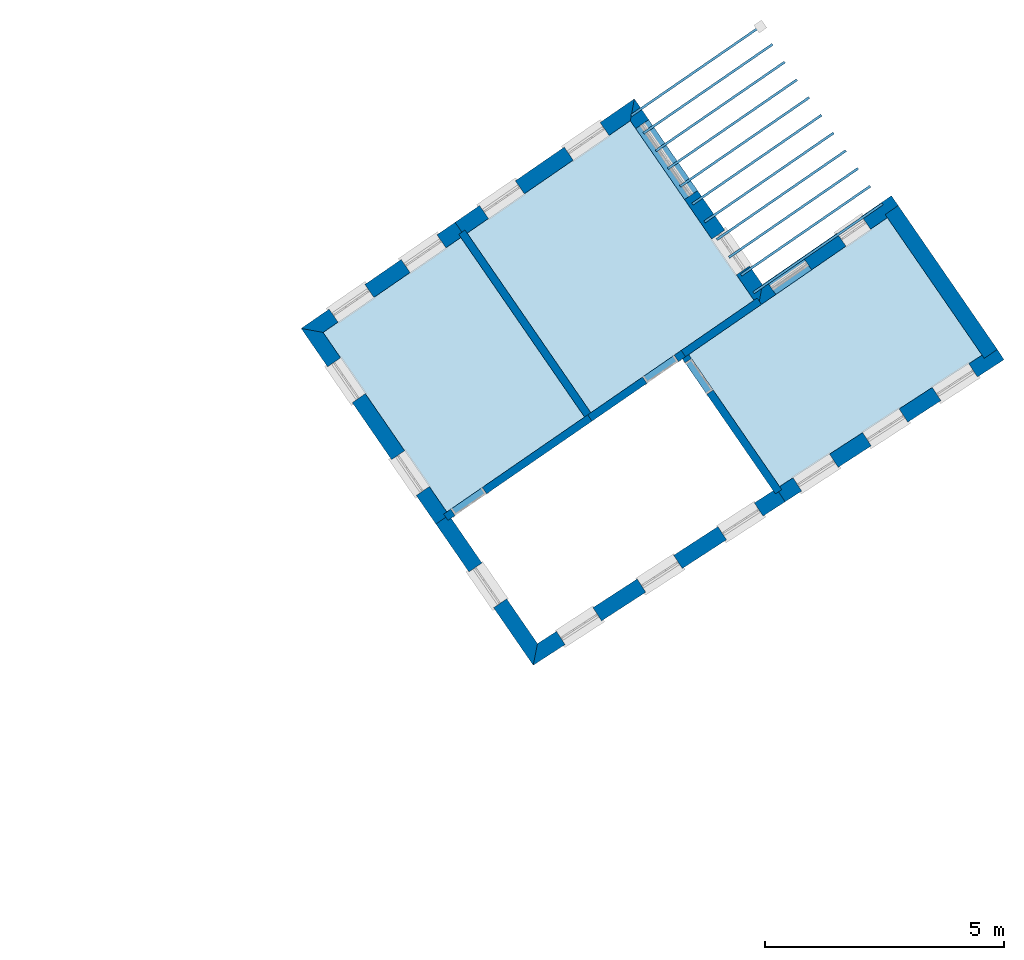
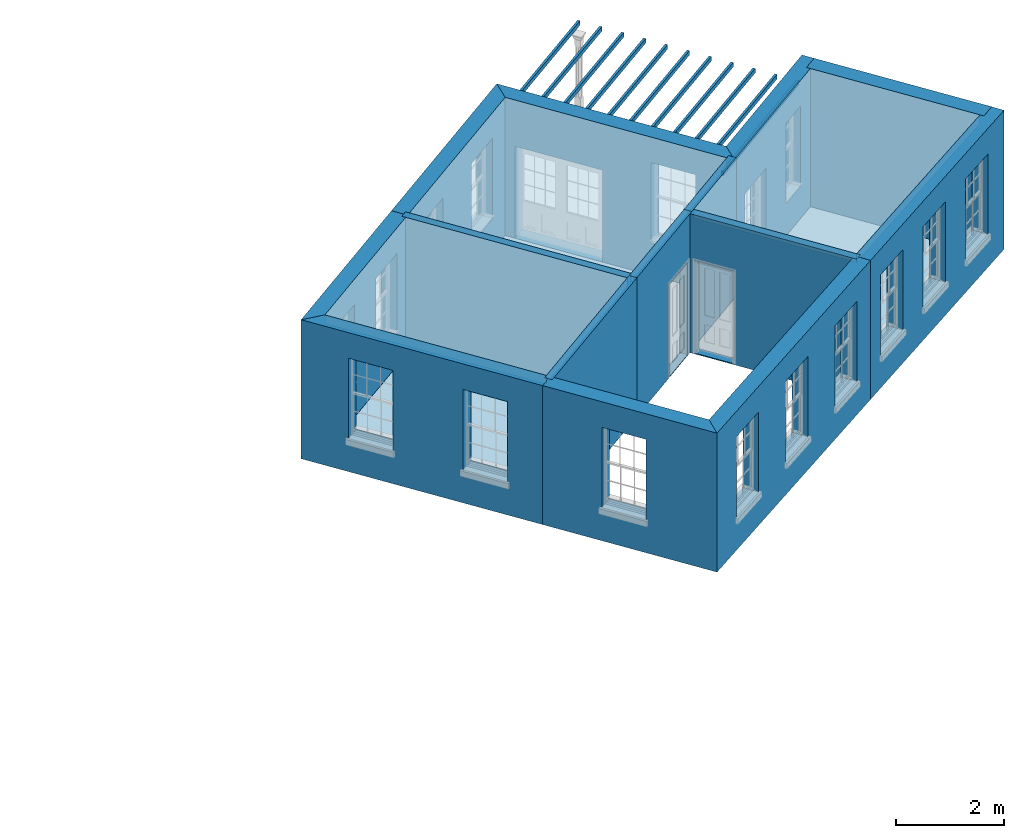
# One storey, part 1 of 12: 17 slabs, 14 walls, 20 openings.
"""IFC2X3 building model written with IfcOpenShell, lengths in metres."""

from ifc_helpers import new_model, si_unit, frame, origin, place, context, subcontext, project, spatial, polyline, outline, extrude, material, layer, layer_set, layer_usage, element, save


model = new_model("IFC2X3")

# Units and contexts
model_context = context("Model", 3, world=origin())
body_context = subcontext(model_context, "Body", "Model", "MODEL_VIEW")
ifc_project = project(units=[si_unit("PLANEANGLEUNIT", "RADIAN"), si_unit("MASSUNIT", "GRAM", prefix="KILO"), si_unit("FORCEUNIT", "NEWTON", prefix="KILO"), si_unit("LENGTHUNIT", "METRE")], contexts=[model_context])

# Site, building, storey
site_placement = place(None, origin())
site = spatial("IfcSite", under=ifc_project, at=site_placement, CompositionType="ELEMENT")
building_placement = place(None, origin())
building = spatial("IfcBuilding", under=site, at=building_placement, Name="Building plot-7", CompositionType="ELEMENT")
storey_placement = place(None, frame((0.0, 0.0, 8.0)))
storey = spatial("IfcBuildingStorey", under=building, at=storey_placement, Name="Floor 1", CompositionType="ELEMENT", Elevation=8.0)

# Slabs
slab_1_placement = place(storey_placement, frame((0.0, 0.0, 2.65)))
element("IfcSlab", 1, at=slab_1_placement, inside=storey, Name="Slab", ObjectType="Slab", PredefinedType="FLOOR", context=body_context, shape_type="SweptSolid", body=[
    extrude(outline(polyline([(85.4408522930304, 71.5516397243826), (85.4692208158621, 71.5104665910024), (88.1660481042133, 73.3685959151946), (88.1376795813816, 73.4097690485749), (85.4408522930304, 71.5516397243826)])), origin(), (0.0, 0.0, 1.0), 0.1),
])
slab_2_placement = place(storey_placement, frame((0.0, 0.0, 2.65)))
element("IfcSlab", 2, at=slab_2_placement, inside=storey, Name="Slab", ObjectType="Slab", PredefinedType="FLOOR", context=body_context, shape_type="SweptSolid", body=[
    extrude(outline(polyline([(85.6961689985157, 71.1810815239604), (85.7245375213474, 71.1399083905801), (88.4213648096985, 72.9980377147724), (88.3929962868668, 73.0392108481526), (85.6961689985157, 71.1810815239604)])), origin(), (0.0, 0.0, 1.0), 0.1),
])
slab_3_placement = place(storey_placement, frame((0.0, 0.0, 2.65)))
element("IfcSlab", 3, at=slab_3_placement, inside=storey, Name="Slab", ObjectType="Slab", PredefinedType="FLOOR", context=body_context, shape_type="SweptSolid", body=[
    extrude(outline(polyline([(85.9514857040009, 70.8105233235381), (85.9798542268326, 70.7693501901579), (88.6766815151838, 72.6274795143502), (88.6483129923521, 72.6686526477304), (85.9514857040009, 70.8105233235381)])), origin(), (0.0, 0.0, 1.0), 0.1),
])
slab_4_placement = place(storey_placement, frame((0.0, 0.0, 2.65)))
element("IfcSlab", 4, at=slab_4_placement, inside=storey, Name="Slab", ObjectType="Slab", PredefinedType="FLOOR", context=body_context, shape_type="SweptSolid", body=[
    extrude(outline(polyline([(86.2068024094861, 70.4399651231159), (86.2351709323178, 70.3987919897357), (88.931998220669, 72.2569213139279), (88.9036296978373, 72.2980944473082), (86.2068024094861, 70.4399651231159)])), origin(), (0.0, 0.0, 1.0), 0.1),
])
slab_5_placement = place(storey_placement, frame((0.0, 0.0, 2.65)))
element("IfcSlab", 5, at=slab_5_placement, inside=storey, Name="Slab", ObjectType="Slab", PredefinedType="FLOOR", context=body_context, shape_type="SweptSolid", body=[
    extrude(outline(polyline([(86.4621191149714, 70.0694069226937), (86.4904876378031, 70.0282337893134), (89.1873149261542, 71.8863631135057), (89.1589464033225, 71.9275362468859), (86.4621191149714, 70.0694069226937)])), origin(), (0.0, 0.0, 1.0), 0.1),
])
slab_6_placement = place(storey_placement, frame((0.0, 0.0, 2.65)))
element("IfcSlab", 6, at=slab_6_placement, inside=storey, Name="Slab", ObjectType="Slab", PredefinedType="FLOOR", context=body_context, shape_type="SweptSolid", body=[
    extrude(outline(polyline([(86.7174358204566, 69.6988487222714), (86.7458043432883, 69.6576755888912), (89.4426316316395, 71.5158049130835), (89.4142631088078, 71.5569780464637), (86.7174358204566, 69.6988487222714)])), origin(), (0.0, 0.0, 1.0), 0.1),
])
slab_7_placement = place(storey_placement, frame((0.0, 0.0, 2.65)))
element("IfcSlab", 7, at=slab_7_placement, inside=storey, Name="Slab", ObjectType="Slab", PredefinedType="FLOOR", context=body_context, shape_type="SweptSolid", body=[
    extrude(outline(polyline([(86.9727525259418, 69.3282905218492), (87.0011210487735, 69.2871173884689), (89.6979483371247, 71.1452467126612), (89.669579814293, 71.1864198460415), (86.9727525259418, 69.3282905218492)])), origin(), (0.0, 0.0, 1.0), 0.1),
])
slab_8_placement = place(storey_placement, frame((0.0, 0.0, 2.65)))
element("IfcSlab", 8, at=slab_8_placement, inside=storey, Name="Slab", ObjectType="Slab", PredefinedType="FLOOR", context=body_context, shape_type="SweptSolid", body=[
    extrude(outline(polyline([(87.228069231427, 68.9577323214269), (87.2564377542587, 68.9165591880467), (89.9532650426099, 70.774688512239), (89.9248965197782, 70.8158616456192), (87.228069231427, 68.9577323214269)])), origin(), (0.0, 0.0, 1.0), 0.1),
])
slab_9_placement = place(storey_placement, frame((0.0, 0.0, 2.65)))
element("IfcSlab", 9, at=slab_9_placement, inside=storey, Name="Slab", ObjectType="Slab", PredefinedType="FLOOR", context=body_context, shape_type="SweptSolid", body=[
    extrude(outline(polyline([(87.4833859369123, 68.5871741210047), (87.511754459744, 68.5460009876245), (90.2085817480952, 70.4041303118168), (90.1802132252635, 70.445303445197), (87.4833859369123, 68.5871741210047)])), origin(), (0.0, 0.0, 1.0), 0.1),
])
slab_10_placement = place(storey_placement, frame((0.0, 0.0, 2.65)))
element("IfcSlab", 10, at=slab_10_placement, inside=storey, Name="Slab", ObjectType="Slab", PredefinedType="FLOOR", context=body_context, shape_type="SweptSolid", body=[
    extrude(outline(polyline([(87.7387026423975, 68.2166159205825), (87.7670711652292, 68.1754427872022), (90.4638984535804, 70.0335721113945), (90.4355299307487, 70.0747452447748), (87.7387026423975, 68.2166159205825)])), origin(), (0.0, 0.0, 1.0), 0.1),
])
slab_11_placement = place(storey_placement, frame((0.0, 0.0, 2.65)))
element("IfcSlab", 11, at=slab_11_placement, inside=storey, Name="Slab", ObjectType="Slab", PredefinedType="FLOOR", context=body_context, shape_type="SweptSolid", body=[
    extrude(outline(polyline([(87.9940193478827, 67.8460577201602), (88.0223878707144, 67.80488458678), (90.7192151590656, 69.6630139109723), (90.6908466362339, 69.7041870443525), (87.9940193478827, 67.8460577201602)])), origin(), (0.0, 0.0, 1.0), 0.1),
])
slab_12_placement = place(storey_placement, frame((0.0, 0.0, 2.95)))
element("IfcSlab", 12, at=slab_12_placement, inside=storey, Name="Slab", ObjectType="Slab", PredefinedType="FLOOR", context=body_context, shape_type="SweptSolid", body=[
    extrude(outline(polyline([(84.6097476417002, 65.3193755674136), (88.0192011182683, 67.6685083842037), (85.4345491775686, 71.4197865077534), (82.0250957010005, 69.0706536909633), (84.6097476417002, 65.3193755674136)])), origin(), (0.0, 0.0, 1.0), 0.2),
])
slab_13_placement = place(storey_placement, frame((0.0, 0.0, 2.95)))
element("IfcSlab", 13, at=slab_13_placement, inside=storey, Name="Slab", ObjectType="Slab", PredefinedType="FLOOR", context=body_context, shape_type="SweptSolid", body=[
    extrude(outline(polyline([(81.8933416741837, 68.9798744179019), (79.01407182865, 66.99604113523), (81.5987237693497, 63.2447630116803), (84.4779936148834, 65.2285962943522), (81.8933416741837, 68.9798744179019)])), origin(), (0.0, 0.0, 1.0), 0.2),
])
slab_14_placement = place(storey_placement, frame((0.0, 0.0, 2.95)))
element("IfcSlab", 14, at=slab_14_placement, inside=storey, Name="Slab", ObjectType="Slab", PredefinedType="FLOOR", context=body_context, shape_type="SweptSolid", body=[
    extrude(outline(polyline([(88.5548521653831, 63.7761292184907), (92.786029707839, 66.5223064579447), (90.8068076796809, 69.3948836815792), (86.6546482173381, 66.5340222207702), (88.5548521653831, 63.7761292184907)])), origin(), (0.0, 0.0, 1.0), 0.2),
])
slab_15_placement = place(storey_placement, origin())
element("IfcSlab", 15, at=slab_15_placement, inside=storey, Name="Slab", ObjectType="Slab", PredefinedType="FLOOR", context=body_context, shape_type="SweptSolid", body=[
    extrude(outline(polyline([(84.6097476417002, 65.3193755674136), (88.0192011182683, 67.6685083842037), (85.4345491775686, 71.4197865077534), (82.0250957010005, 69.0706536909633), (84.6097476417002, 65.3193755674136)])), origin(), (0.0, 0.0, 1.0), 0.02),
])
slab_16_placement = place(storey_placement, origin())
element("IfcSlab", 16, at=slab_16_placement, inside=storey, Name="Slab", ObjectType="Slab", PredefinedType="FLOOR", context=body_context, shape_type="SweptSolid", body=[
    extrude(outline(polyline([(81.8933416741837, 68.9798744179019), (79.01407182865, 66.99604113523), (81.5987237693497, 63.2447630116803), (84.4779936148834, 65.2285962943522), (81.8933416741837, 68.9798744179019)])), origin(), (0.0, 0.0, 1.0), 0.02),
])
slab_17_placement = place(storey_placement, origin())
element("IfcSlab", 17, at=slab_17_placement, inside=storey, Name="Slab", ObjectType="Slab", PredefinedType="FLOOR", context=body_context, shape_type="SweptSolid", body=[
    extrude(outline(polyline([(88.5548521653831, 63.7761292184907), (92.786029707839, 66.5223064579447), (90.8068076796809, 69.3948836815792), (86.6546482173381, 66.5340222207702), (88.5548521653831, 63.7761292184907)])), origin(), (0.0, 0.0, 1.0), 0.02),
])

# Wall, openings
ifc_material_1 = material(Name="Masonry")
ifc_layer_1 = layer(ifc_material_1, 0.33, ventilated=False)
ifc_layer_set_1 = layer_set([ifc_layer_1], Name="My Wall")
ifc_layer_usage_1 = layer_usage(ifc_layer_set_1, "AXIS2", "NEGATIVE", 0.08)
wall_1_placement = place(storey_placement, origin())
wall_1 = element("IfcWallStandardCase", 18, at=wall_1_placement, inside=storey, material=ifc_layer_usage_1, Name="exterior", context=body_context, shape_type="SweptSolid", body=[
    extrude(outline(polyline([(91.0785503599906, 69.5821159322684), (90.8913181093014, 69.853858612578), (88.1944908209502, 67.9957292883857), (88.1099803913297, 67.5367543573869), (91.0785503599906, 69.5821159322684)])), origin(), (0.0, 0.0, 1.0), 3.15),
])
opening_1_placement = place(storey_placement, frame((0.0, 0.0, 0.75)))
element("IfcOpeningElement", 19, at=opening_1_placement, cuts=wall_1, Name="Opening", ObjectType="Opening", context=body_context, shape_type="SweptSolid", body=[
    extrude(outline(polyline([(90.2685777039389, 69.4247869350695), (89.7539135366858, 69.0701803996734), (89.9411457873749, 68.7984377193637), (90.4558099546281, 69.1530442547599), (90.2685777039389, 69.4247869350695)])), origin(), (0.0, 0.0, 1.0), 1.82),
])
opening_2_placement = place(storey_placement, frame((0.0, 0.0, 0.0199999999999996)))
element("IfcOpeningElement", 20, at=opening_2_placement, cuts=wall_1, Name="Opening", ObjectType="Opening", context=body_context, shape_type="SweptSolid", body=[
    extrude(outline(polyline([(89.037507489897, 68.5765725630437), (88.2881564623765, 68.0602654475069), (88.4753887130656, 67.7885227671973), (89.2247397405862, 68.3048298827341), (89.037507489897, 68.5765725630437)])), origin(), (0.0, 0.0, 1.0), 2.08),
])

wall_2_placement = place(storey_placement, origin())
wall_2 = element("IfcWallStandardCase", 21, at=wall_2_placement, inside=storey, material=ifc_layer_usage_1, Name="exterior", context=body_context, shape_type="SweptSolid", body=[
    extrude(outline(polyline([(88.1099803913297, 67.5367543573869), (88.1944908209502, 67.9957292883857), (85.5190596071891, 71.8787614387522), (85.4345491775686, 71.4197865077534), (88.1099803913297, 67.5367543573869)])), origin(), (0.0, 0.0, 1.0), 3.15),
])
opening_3_placement = place(storey_placement, frame((0.0, 0.0, 0.75)))
element("IfcOpeningElement", 22, at=opening_3_placement, cuts=wall_2, Name="Opening", ObjectType="Opening", context=body_context, shape_type="SweptSolid", body=[
    extrude(outline(polyline([(87.9256291894368, 68.3859461453158), (87.4093220739, 69.1352971728363), (87.1375793935903, 68.9480649221472), (87.6538865091271, 68.1987138946266), (87.9256291894368, 68.3859461453158)])), origin(), (0.0, 0.0, 1.0), 1.82),
])
opening_4_placement = place(storey_placement, frame((0.0, 0.0, 0.0199999999999996)))
element("IfcOpeningElement", 23, at=opening_4_placement, cuts=wall_2, Name="Opening", ObjectType="Opening", context=body_context, shape_type="SweptSolid", body=[
    extrude(outline(polyline([(86.8403934357583, 69.9610213334149), (85.8191266138174, 71.4432541351038), (85.5473839335077, 71.2560218844146), (86.5686507554486, 69.7737890827257), (86.8403934357583, 69.9610213334149)])), origin(), (0.0, 0.0, 1.0), 2.08),
])

wall_3_placement = place(storey_placement, origin())
wall_3 = element("IfcWallStandardCase", 24, at=wall_3_placement, inside=storey, material=ifc_layer_usage_1, Name="exterior", context=body_context, shape_type="SweptSolid", body=[
    extrude(outline(polyline([(85.4345491775686, 71.4197865077534), (85.5190596071891, 71.8787614387522), (81.7719864369029, 69.2970067347422), (81.9592186875921, 69.0252640544326), (85.4345491775686, 71.4197865077534)])), origin(), (0.0, 0.0, 1.0), 3.15),
])
opening_5_placement = place(storey_placement, frame((0.0, 0.0, 0.75)))
element("IfcOpeningElement", 25, at=opening_5_placement, cuts=wall_3, Name="Opening", ObjectType="Opening", context=body_context, shape_type="SweptSolid", body=[
    extrude(outline(polyline([(84.8025675782019, 71.3850943598993), (84.0532165506813, 70.8687872443625), (84.2404488013705, 70.5970445640528), (84.9897998288911, 71.1133516795896), (84.8025675782019, 71.3850943598993)])), origin(), (0.0, 0.0, 1.0), 1.82),
])
opening_6_placement = place(storey_placement, frame((0.0, 0.0, 0.75)))
element("IfcOpeningElement", 26, at=opening_6_placement, cuts=wall_3, Name="Opening", ObjectType="Opening", context=body_context, shape_type="SweptSolid", body=[
    extrude(outline(polyline([(83.0319638265094, 70.1651383149735), (82.2826127989889, 69.6488311994367), (82.4698450496781, 69.3770885191271), (83.2191960771986, 69.8933956346639), (83.0319638265094, 70.1651383149735)])), origin(), (0.0, 0.0, 1.0), 1.82),
])

wall_4_placement = place(storey_placement, origin())
wall_4 = element("IfcWallStandardCase", 27, at=wall_4_placement, inside=storey, material=ifc_layer_usage_1, Name="exterior", context=body_context, shape_type="SweptSolid", body=[
    extrude(outline(polyline([(81.9592186875921, 69.0252640544326), (81.7719864369029, 69.2970067347422), (78.5550968976512, 67.0805515648505), (79.01407182865, 66.99604113523), (81.9592186875921, 69.0252640544326)])), origin(), (0.0, 0.0, 1.0), 3.15),
])
opening_7_placement = place(storey_placement, frame((0.0, 0.0, 0.75)))
element("IfcOpeningElement", 28, at=opening_7_placement, cuts=wall_4, Name="Opening", ObjectType="Opening", context=body_context, shape_type="SweptSolid", body=[
    extrude(outline(polyline([(81.3939059825756, 69.0365071535773), (80.644554955055, 68.5202000380405), (80.8317872057442, 68.2484573577309), (81.5811382332648, 68.7647644732677), (81.3939059825756, 69.0365071535773)])), origin(), (0.0, 0.0, 1.0), 1.82),
])
opening_8_placement = place(storey_placement, frame((0.0, 0.0, 0.75)))
element("IfcOpeningElement", 29, at=opening_8_placement, cuts=wall_4, Name="Opening", ObjectType="Opening", context=body_context, shape_type="SweptSolid", body=[
    extrude(outline(polyline([(79.8883940464003, 67.9992008757107), (79.1390430188798, 67.4828937601739), (79.326275269569, 67.2111510798642), (80.0756262970895, 67.727458195401), (79.8883940464003, 67.9992008757107)])), origin(), (0.0, 0.0, 1.0), 1.82),
])

wall_5_placement = place(storey_placement, origin())
wall_5 = element("IfcWallStandardCase", 30, at=wall_5_placement, inside=storey, material=ifc_layer_usage_1, Name="exterior", context=body_context, shape_type="SweptSolid", body=[
    extrude(outline(polyline([(79.01407182865, 66.99604113523), (78.5550968976512, 67.0805515648505), (81.3723707255707, 62.9916537475827), (81.6441134058804, 63.1788859982719), (79.01407182865, 66.99604113523)])), origin(), (0.0, 0.0, 1.0), 3.15),
])
opening_9_placement = place(storey_placement, frame((0.0, 0.0, 0.75)))
element("IfcOpeningElement", 31, at=opening_9_placement, cuts=wall_5, Name="Opening", ObjectType="Opening", context=body_context, shape_type="SweptSolid", body=[
    extrude(outline(polyline([(79.1076437574815, 66.2786033741179), (79.6239508730183, 65.5292523465973), (79.895693553328, 65.7164845972865), (79.3793864377912, 66.465835624807), (79.1076437574815, 66.2786033741179)])), origin(), (0.0, 0.0, 1.0), 1.82),
])
opening_10_placement = place(storey_placement, frame((0.0, 0.0, 0.75)))
element("IfcOpeningElement", 32, at=opening_10_placement, cuts=wall_5, Name="Opening", ObjectType="Opening", context=body_context, shape_type="SweptSolid", body=[
    extrude(outline(polyline([(80.4453593643621, 64.3370872989346), (80.9616664798989, 63.5877362714141), (81.2334091602085, 63.7749685221033), (80.7171020446717, 64.5243195496238), (80.4453593643621, 64.3370872989346)])), origin(), (0.0, 0.0, 1.0), 1.82),
])

# Wall, opening
wall_6_placement = place(storey_placement, origin())
wall_6 = element("IfcWallStandardCase", 33, at=wall_6_placement, inside=storey, material=ifc_layer_usage_1, Name="exterior", context=body_context, shape_type="SweptSolid", body=[
    extrude(outline(polyline([(81.6441134058804, 63.1788859982719), (81.3723707255707, 62.9916537475827), (83.4056068548288, 60.0406822486382), (83.4952173055673, 60.4922551780955), (81.6441134058804, 63.1788859982719)])), origin(), (0.0, 0.0, 1.0), 3.15),
])
opening_11_placement = place(storey_placement, frame((0.0, 0.0, 0.75)))
element("IfcOpeningElement", 34, at=opening_11_placement, cuts=wall_6, Name="Opening", ObjectType="Opening", context=body_context, shape_type="SweptSolid", body=[
    extrude(outline(polyline([(82.0618457515332, 61.9909725568587), (82.57815286707, 61.2416215293381), (82.8498955473796, 61.4288537800273), (82.3335884318428, 62.1782048075478), (82.0618457515332, 61.9909725568587)])), origin(), (0.0, 0.0, 1.0), 1.82),
])

# Wall, openings
wall_7_placement = place(storey_placement, origin())
wall_7 = element("IfcWallStandardCase", 35, at=wall_7_placement, inside=storey, material=ifc_layer_usage_1, Name="exterior", context=body_context, shape_type="SweptSolid", body=[
    extrude(outline(polyline([(83.4952173055673, 60.4922551780955), (83.4056068548288, 60.0406822486382), (88.6692330397849, 63.4569535539851), (88.4895749413382, 63.7337620937061), (83.4952173055673, 60.4922551780955)])), origin(), (0.0, 0.0, 1.0), 3.15),
])
opening_12_placement = place(storey_placement, frame((0.0, 0.0, 0.75)))
element("IfcOpeningElement", 36, at=opening_12_placement, cuts=wall_7, Name="Opening", ObjectType="Opening", context=body_context, shape_type="SweptSolid", body=[
    extrude(outline(polyline([(84.0712103972928, 60.4726814451913), (84.8345309159174, 60.9681022621203), (84.6548728174706, 61.2449108018413), (83.891552298846, 60.7494899849123), (84.0712103972928, 60.4726814451913)])), origin(), (0.0, 0.0, 1.0), 1.82),
])
opening_13_placement = place(storey_placement, frame((0.0, 0.0, 0.75)))
element("IfcOpeningElement", 37, at=opening_13_placement, cuts=wall_7, Name="Opening", ObjectType="Opening", context=body_context, shape_type="SweptSolid", body=[
    extrude(outline(polyline([(85.7577553505647, 61.567306125323), (86.5210758691894, 62.062726942252), (86.3414177707426, 62.339535481973), (85.5780972521179, 61.844114665044), (85.7577553505647, 61.567306125323)])), origin(), (0.0, 0.0, 1.0), 1.82),
])
opening_14_placement = place(storey_placement, frame((0.0, 0.0, 0.75)))
element("IfcOpeningElement", 38, at=opening_14_placement, cuts=wall_7, Name="Opening", ObjectType="Opening", context=body_context, shape_type="SweptSolid", body=[
    extrude(outline(polyline([(87.4443003038367, 62.6619308054547), (88.2076208224613, 63.1573516223838), (88.0279627240145, 63.4341601621048), (87.2646422053899, 62.9387393451758), (87.4443003038367, 62.6619308054547)])), origin(), (0.0, 0.0, 1.0), 1.82),
])

wall_8_placement = place(storey_placement, origin())
wall_8 = element("IfcWallStandardCase", 39, at=wall_8_placement, inside=storey, material=ifc_layer_usage_1, Name="exterior", context=body_context, shape_type="SweptSolid", body=[
    extrude(outline(polyline([(88.4895749413382, 63.7337620937061), (88.6692330397849, 63.4569535539851), (93.2443754062405, 66.4263755902746), (93.0647173077938, 66.7031841299957), (88.4895749413382, 63.7337620937061)])), origin(), (0.0, 0.0, 1.0), 3.15),
])
opening_15_placement = place(storey_placement, frame((0.0, 0.0, 0.75)))
element("IfcOpeningElement", 40, at=opening_15_placement, cuts=wall_8, Name="Opening", ObjectType="Opening", context=body_context, shape_type="SweptSolid", body=[
    extrude(outline(polyline([(89.0151459350181, 63.6814627148963), (89.7784664536428, 64.1768835318253), (89.598808355196, 64.4536920715463), (88.8354878365713, 63.9582712546173), (89.0151459350181, 63.6814627148963)])), origin(), (0.0, 0.0, 1.0), 1.82),
])
opening_16_placement = place(storey_placement, frame((0.0, 0.0, 0.75)))
element("IfcOpeningElement", 41, at=opening_16_placement, cuts=wall_8, Name="Opening", ObjectType="Opening", context=body_context, shape_type="SweptSolid", body=[
    extrude(outline(polyline([(90.4702922441091, 64.6259018536476), (91.2336127627338, 65.1213226705767), (91.053954664287, 65.3981312102977), (90.2906341456623, 64.9027103933687), (90.4702922441091, 64.6259018536476)])), origin(), (0.0, 0.0, 1.0), 1.82),
])
opening_17_placement = place(storey_placement, frame((0.0, 0.0, 0.75)))
element("IfcOpeningElement", 42, at=opening_17_placement, cuts=wall_8, Name="Opening", ObjectType="Opening", context=body_context, shape_type="SweptSolid", body=[
    extrude(outline(polyline([(91.9254385532001, 65.570340992399), (92.6887590718248, 66.065761809328), (92.509100973378, 66.342570349049), (91.7457804547533, 65.84714953212), (91.9254385532001, 65.570340992399)])), origin(), (0.0, 0.0, 1.0), 1.82),
])

# Wall
wall_9_placement = place(storey_placement, origin())
element("IfcWallStandardCase", 43, at=wall_9_placement, inside=storey, material=ifc_layer_usage_1, Name="party", context=body_context, shape_type="SweptSolid", body=[
    extrude(outline(polyline([(92.8326903336141, 66.4545847728911), (93.1044330139238, 66.6418170235803), (91.0331607234598, 69.6479929456768), (90.7614180431502, 69.4607606949876), (92.8326903336141, 66.4545847728911)])), origin(), (0.0, 0.0, 1.0), 3.15),
])

# Wall, opening
ifc_material_2 = material(Name="Masonry")
ifc_layer_2 = layer(ifc_material_2, 0.16, ventilated=False)
ifc_layer_set_2 = layer_set([ifc_layer_2], Name="My Wall")
ifc_layer_usage_2 = layer_usage(ifc_layer_set_2, "AXIS2", "NEGATIVE", 0.08)
wall_10_placement = place(storey_placement, origin())
wall_10 = element("IfcWallStandardCase", 44, at=wall_10_placement, inside=storey, material=ifc_layer_usage_2, Name="interior", context=body_context, shape_type="SweptSolid", body=[
    extrude(outline(polyline([(84.6346499013532, 65.1422319040661), (84.5438706282918, 65.2739859308829), (81.5328467559413, 63.1993733751496), (81.6236260290027, 63.0676193483328), (84.6346499013532, 65.1422319040661)])), origin(), (0.0, 0.0, 1.0), 3.15),
])
opening_18_placement = place(storey_placement, frame((0.0, 0.0, 0.0199999999999996)))
element("IfcOpeningElement", 45, at=opening_18_placement, cuts=wall_10, Name="Opening", ObjectType="Opening", context=body_context, shape_type="SweptSolid", body=[
    extrude(outline(polyline([(82.3398401701942, 63.7553964226508), (81.6810700361102, 63.3015000573437), (81.7718493091716, 63.1697460305269), (82.4306194432556, 63.623642395834), (82.3398401701942, 63.7553964226508)])), origin(), (0.0, 0.0, 1.0), 2.1),
])

# Wall
wall_11_placement = place(storey_placement, origin())
element("IfcWallStandardCase", 46, at=wall_11_placement, inside=storey, material=ifc_layer_usage_2, Name="interior", context=body_context, shape_type="SweptSolid", body=[
    extrude(outline(polyline([(84.5233832514141, 65.1627192809438), (84.6551372782309, 65.2534985540052), (81.9797060644698, 69.1365307043717), (81.847952037653, 69.0457514313103), (84.5233832514141, 65.1627192809438)])), origin(), (0.0, 0.0, 1.0), 3.15),
])

# Wall, opening
wall_12_placement = place(storey_placement, origin())
wall_12 = element("IfcWallStandardCase", 47, at=wall_12_placement, inside=storey, material=ifc_layer_usage_2, Name="interior", context=body_context, shape_type="SweptSolid", body=[
    extrude(outline(polyline([(86.5887712039297, 66.4886325842395), (86.4979919308683, 66.6203866110563), (84.5438706282918, 65.2739859308829), (84.6346499013532, 65.1422319040661), (86.5887712039297, 66.4886325842395)])), origin(), (0.0, 0.0, 1.0), 3.15),
])
opening_19_placement = place(storey_placement, frame((0.0, 0.0, 0.0199999999999996)))
element("IfcOpeningElement", 48, at=opening_19_placement, cuts=wall_12, Name="Opening", ObjectType="Opening", context=body_context, shape_type="SweptSolid", body=[
    extrude(outline(polyline([(86.3497686506994, 66.5182599288622), (85.6909985166154, 66.0643635635551), (85.7817777896768, 65.9326095367383), (86.4405479237608, 66.3865059020454), (86.3497686506994, 66.5182599288622)])), origin(), (0.0, 0.0, 1.0), 2.1),
])

wall_13_placement = place(storey_placement, origin())
wall_13 = element("IfcWallStandardCase", 49, at=wall_13_placement, inside=storey, material=ifc_layer_usage_2, Name="interior", context=body_context, shape_type="SweptSolid", body=[
    extrude(outline(polyline([(86.6092585808074, 66.5998992341786), (86.4775045539906, 66.5091199611172), (88.4672514063411, 63.621267356637), (88.5990054331579, 63.7120466296984), (86.6092585808074, 66.5998992341786)])), origin(), (0.0, 0.0, 1.0), 3.15),
])
opening_20_placement = place(storey_placement, frame((0.0, 0.0, 0.0199999999999996)))
element("IfcOpeningElement", 50, at=opening_20_placement, cuts=wall_13, Name="Opening", ObjectType="Opening", context=body_context, shape_type="SweptSolid", body=[
    extrude(outline(polyline([(86.5796312361847, 66.3608966809483), (87.0335276014918, 65.7021265468643), (87.1652816283086, 65.7929058199257), (86.7113852630015, 66.4516759540097), (86.5796312361847, 66.3608966809483)])), origin(), (0.0, 0.0, 1.0), 2.1),
])

# Wall
wall_14_placement = place(storey_placement, origin())
element("IfcWallStandardCase", 51, at=wall_14_placement, inside=storey, material=ifc_layer_usage_2, Name="interior", context=body_context, shape_type="SweptSolid", body=[
    extrude(outline(polyline([(86.4979919308683, 66.6203866110563), (86.5887712039297, 66.4886325842395), (88.1758574047381, 67.5821439939176), (88.0850781316767, 67.7138980207344), (86.4979919308683, 66.6203866110563)])), origin(), (0.0, 0.0, 1.0), 3.15),
])

save(model, "model.ifc")
